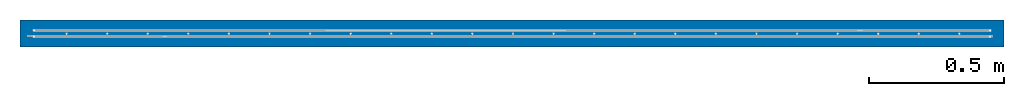
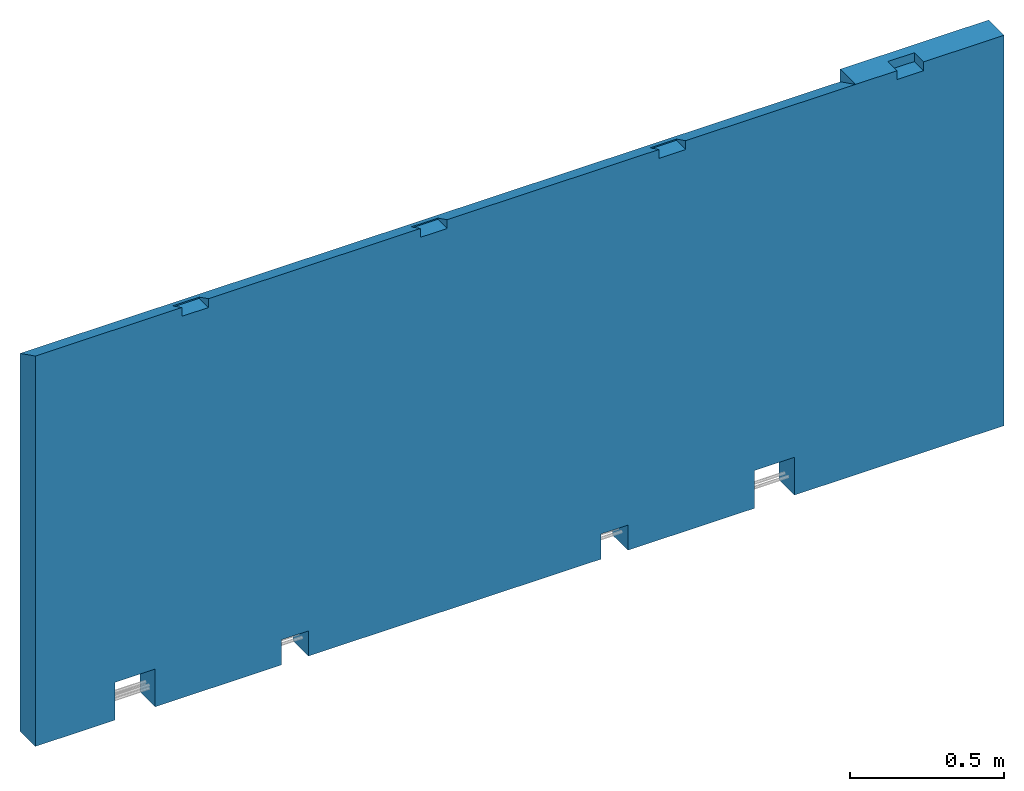
# One storey, part 3 of 3: 1 wall, 1 element without a shape of its own.
"""IFC2X3 building model written with IfcOpenShell, lengths in millimetres."""

from ifc_helpers import new_model, si_unit, frame, origin_with_axes, place, context, subcontext, project, spatial, faceted_brep, material, type_object, element, aggregate, save


model = new_model("IFC2X3")

# Units and contexts
model_context = context("Model", 3, precision=1e-05, world=origin_with_axes())
body_context = subcontext(model_context, "Body", "Model", "MODEL_VIEW")
ifc_project = project(units=[si_unit("LENGTHUNIT", "METRE", prefix="MILLI"), si_unit("AREAUNIT", "SQUARE_METRE"), si_unit("VOLUMEUNIT", "CUBIC_METRE"), si_unit("MASSUNIT", "GRAM", prefix="KILO"), si_unit("TIMEUNIT", "SECOND"), si_unit("PLANEANGLEUNIT", "RADIAN"), si_unit("SOLIDANGLEUNIT", "STERADIAN"), si_unit("THERMODYNAMICTEMPERATUREUNIT", "DEGREE_CELSIUS"), si_unit("LUMINOUSINTENSITYUNIT", "LUMEN")], contexts=[model_context])

# Site, building, storey
site_placement = place(None, origin_with_axes())
site = spatial("IfcSite", under=ifc_project, at=site_placement, CompositionType="ELEMENT")
building_placement = place(site_placement, origin_with_axes())
building = spatial("IfcBuilding", under=site, at=building_placement, Name="1", CompositionType="ELEMENT")
storey_placement = place(building_placement, origin_with_axes())
storey = spatial("IfcBuildingStorey", under=building, at=storey_placement, CompositionType="ELEMENT", Elevation=0.0)

# Assembly, wall
assembly_placement = place(storey_placement, origin_with_axes())
assembly = element("IfcElementAssembly", 1, at=assembly_placement, inside=storey, AssemblyPlace="NOTDEFINED", PredefinedType="REINFORCEMENT_UNIT")
ifc_material = material(Name="CONCRETE/C35/45")
wall_type = type_object("IfcWallType", Name="1550X100", PredefinedType="NOTDEFINED")
wall_placement = place(assembly_placement, frame((36000.0, 12049.999279727, 775.550894571708), z_axis=(0.0, 0.0, 1.0), x_axis=(1.0, 0.0, 0.0)))
wall = element("IfcWall", 2, at=wall_placement, type_object=wall_type, material=ifc_material, ObjectType="1550X100", context=body_context, shape_type="Brep", body=[
    faceted_brep([(0.0, 50.0, 725.000000000007), (0.0, -50.0, 775.0), (549.99602530642, -50.0, 775.0), (549.996670424909, 10.0003600811324, 745.043837171145), (649.996670542962, 10.0003095067968, 745.039110463558), (649.996025285349, -50.0, 775.0), (1445.97602529373, -50.0, 775.0), (1445.97667128137, 9.99990751628866, 745.001486530884), (1545.97667139943, 9.99985694195493, 744.996759823296), (1545.97602527266, -50.0, 775.0), (2341.95602530148, -50.0, 775.0), (2341.95667215829, 9.99945490269238, 744.959135915007), (2441.95667227634, 9.99940432835865, 744.95440920742), (2441.95602528041, -50.0, 775.0), (3079.65999408099, -50.0, 775.0), (3079.66949267787, 49.8362778510655, 725.000000000007), (3079.66949267787, 49.8362778510655, 774.999999999925), (2441.95674358548, -50.0003775534442, 740.000502640579), (2441.95677394538, 9.99942308477148, 740.000502640579), (2341.95677396645, 9.99947368477297, 739.998450340579), (2341.95674360655, -50.0003269534427, 739.998450340579), (1545.97674357772, -49.9999247795004, 740.000502640579), (1545.97677393763, 9.99987585871531, 740.000502640579), (1445.9767739587, 9.9999264587168, 739.998450340579), (1445.9767435988, -49.9998741794989, 739.998450340579), (649.996743590418, -49.9994720542982, 740.000502640579), (649.996773950319, 10.000328583903, 740.000502640579), (549.99677397139, 10.0003791839044, 739.998450340579), (549.996743611489, -49.9994214542967, 739.998450340579), (3234.9360556941, 9.99889288441409, 774.998450333208), (3234.93677399917, 9.99902540093535, 739.998450340579), (3334.9367739781, 9.99897480093387, 740.000502640579), (3334.93605567303, 9.99884228441078, 775.000502633208), (3234.9360253342, -50.0, 775.0), (3234.93674363927, -50.0007752372803, 739.998450340579), (3334.9367436182, -50.0008258372818, 740.000502640579), (3334.93602531313, -50.0, 775.0), (0.0, -50.0, -775.0), (0.0, 50.0, -775.0), (299.754469846812, 50.0, -775.0), (299.754419346813, -50.0, -775.0), (299.754469846812, 50.0, -625.000762764001), (299.754419346813, -50.0, -625.000762764001), (449.754469846834, 50.0, -625.000762764001), (449.754419346835, -50.0, -625.000762764001), (449.754469846841, 50.0, -775.0), (449.754419346842, -50.0, -775.0), (924.754469843683, 50.0, -775.0), (924.754419343684, -50.0, -775.0), (924.754469843683, 50.0, -675.000762764001), (924.754419343684, -50.0, -675.000762764001), (1024.75446984369, 50.0, -675.000762764001), (1024.75441934369, -50.0, -675.000762764001), (1024.75446984369, 50.0, -775.0), (1024.75441934369, -50.0, -775.0), (2124.75446986646, 50.0, -775.0), (2124.75441936646, -50.0, -775.0), (2124.75446986646, 50.0, -675.000762764001), (2124.75441936646, -50.0, -675.000762764001), (2224.75446986646, 50.0, -675.000762764001), (2224.75441936647, -50.0, -675.000762764001), (2224.75446986646, 50.0, -775.0), (2224.75441936647, -50.0, -775.0), (2699.75446985518, 50.0, -775.0), (2699.75441935518, -50.0, -775.0), (2699.75446985518, 50.0, -625.000762764001), (2699.75441935518, -50.0, -625.000762764001), (2849.7544698552, 50.0, -625.000762764001), (2849.7544193552, -50.0, -625.000762764001), (2849.7544698552, 50.0, -775.0), (2849.7544193552, -50.0, -775.0), (3637.09950262025, 50.0, -775.0), (3637.09950262025, -50.0, -775.0), (3637.09950262025, -50.0, 775.0), (3637.09950262025, 50.0, 775.0)], [[[0, 1, 2, 3, 4, 5, 6, 7, 8, 9, 10, 11, 12, 13, 14, 15]], [[16, 15, 14]], [[17, 18, 19, 20]], [[18, 17, 13, 12]], [[19, 18, 12, 11]], [[20, 19, 11, 10]], [[21, 22, 23, 24]], [[22, 21, 9, 8]], [[23, 22, 8, 7]], [[24, 23, 7, 6]], [[25, 26, 27, 28]], [[26, 25, 5, 4]], [[27, 26, 4, 3]], [[28, 27, 3, 2]], [[29, 30, 31, 32]], [[33, 34, 30, 29]], [[35, 31, 30, 34]], [[32, 31, 35, 36]], [[37, 38, 39, 40]], [[41, 42, 40, 39]], [[43, 44, 42, 41]], [[45, 46, 44, 43]], [[46, 45, 47, 48]], [[49, 50, 48, 47]], [[51, 52, 50, 49]], [[53, 54, 52, 51]], [[55, 56, 54, 53]], [[57, 58, 56, 55]], [[59, 60, 58, 57]], [[61, 62, 60, 59]], [[63, 64, 62, 61]], [[65, 66, 64, 63]], [[67, 68, 66, 65]], [[69, 70, 68, 67]], [[71, 72, 70, 69]], [[73, 72, 71, 74]], [[33, 29, 32, 36, 73, 74, 16, 14]], [[17, 20, 10, 9, 21, 24, 6, 5, 25, 28, 2, 1, 37, 40, 42, 44, 46, 48, 50, 52, 54, 56, 58, 60, 62, 64, 66, 68, 70, 72, 73, 36, 35, 34, 33, 14, 13]], [[38, 37, 1, 0]], [[74, 71, 69, 67, 65, 63, 61, 59, 57, 55, 53, 51, 49, 47, 45, 43, 41, 39, 38, 0, 15, 16]]]),
])
aggregate(assembly, [wall])

save(model, "model.ifc")
